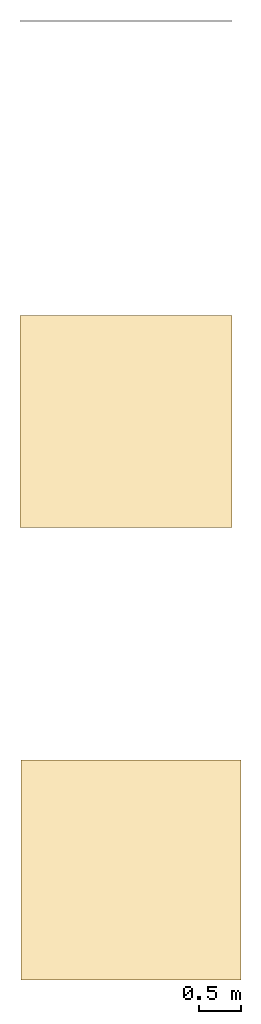
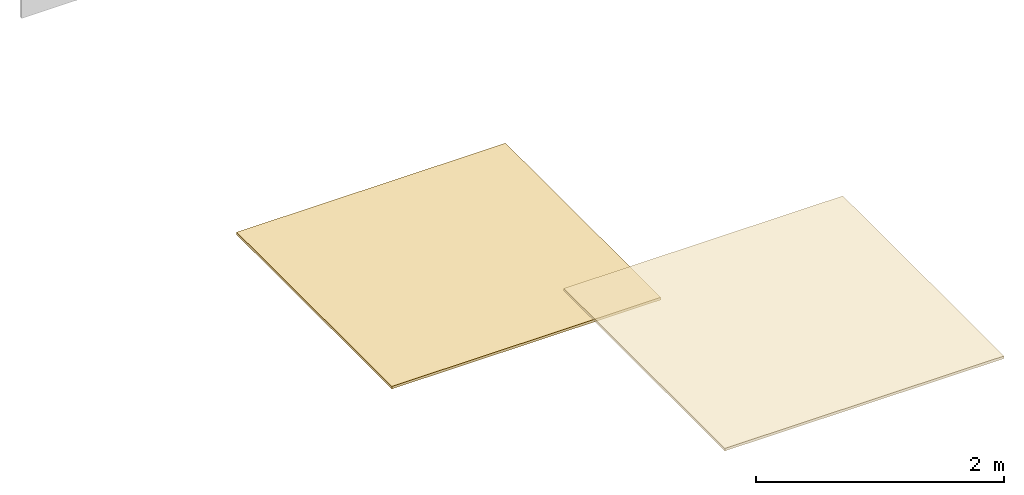
# One storey, part 2 of 2: 2 coverings.
"""IFC2X3 building model written with IfcOpenShell, lengths in millimetres."""

from ifc_helpers import new_model, entity, si_unit, converted_unit, derived_unit, direction, frame, frame_2d, origin, place, context, subcontext, project, spatial, rectangle, extrude, material, layer, layer_set, layer_usage, type_object, element, save


model = new_model("IFC2X3")

# Units and contexts
model_context = context("Model", 3, precision=0.01, world=origin(), true_north=direction((6.12303176911189e-17, 1.0)))
body_context = subcontext(model_context, "Body", "Model", "MODEL_VIEW")
ifc_project = project(units=[si_unit("LENGTHUNIT", "METRE", prefix="MILLI"), si_unit("AREAUNIT", "SQUARE_METRE"), si_unit("VOLUMEUNIT", "CUBIC_METRE"), converted_unit("PLANEANGLEUNIT", "DEGREE", entity("IfcRatioMeasure", 0.0174532925199433), si_unit("PLANEANGLEUNIT", "RADIAN"), dimensions=[0, 0, 0, 0, 0, 0, 0]), si_unit("MASSUNIT", "GRAM", prefix="KILO"), derived_unit("MASSDENSITYUNIT", [(si_unit("MASSUNIT", "GRAM", prefix="KILO"), 1), (si_unit("LENGTHUNIT", "METRE"), -3)]), si_unit("TIMEUNIT", "SECOND"), si_unit("FREQUENCYUNIT", "HERTZ"), si_unit("THERMODYNAMICTEMPERATUREUNIT", "DEGREE_CELSIUS"), derived_unit("THERMALTRANSMITTANCEUNIT", [(si_unit("MASSUNIT", "GRAM", prefix="KILO"), 1), (si_unit("THERMODYNAMICTEMPERATUREUNIT", "KELVIN"), -1), (si_unit("TIMEUNIT", "SECOND"), -3)]), derived_unit("VOLUMETRICFLOWRATEUNIT", [(si_unit("LENGTHUNIT", "METRE"), 3), (si_unit("TIMEUNIT", "SECOND"), -1)]), si_unit("ELECTRICCURRENTUNIT", "AMPERE"), si_unit("ELECTRICVOLTAGEUNIT", "VOLT"), si_unit("POWERUNIT", "WATT"), si_unit("FORCEUNIT", "NEWTON", prefix="KILO"), si_unit("ILLUMINANCEUNIT", "LUX"), si_unit("LUMINOUSFLUXUNIT", "LUMEN"), si_unit("LUMINOUSINTENSITYUNIT", "CANDELA"), derived_unit("USERDEFINED", [(si_unit("MASSUNIT", "GRAM", prefix="KILO"), -1), (si_unit("LENGTHUNIT", "METRE"), -2), (si_unit("TIMEUNIT", "SECOND"), 3), (si_unit("LUMINOUSFLUXUNIT", "LUMEN"), 1)]), derived_unit("LINEARVELOCITYUNIT", [(si_unit("LENGTHUNIT", "METRE"), 1), (si_unit("TIMEUNIT", "SECOND"), -1)]), si_unit("PRESSUREUNIT", "PASCAL"), derived_unit("USERDEFINED", [(si_unit("LENGTHUNIT", "METRE"), -2), (si_unit("MASSUNIT", "GRAM", prefix="KILO"), 1), (si_unit("TIMEUNIT", "SECOND"), -2)])], contexts=[model_context])

# Site, building, storey
site_placement = place(None, origin())
site = spatial("IfcSite", under=ifc_project, at=site_placement, CompositionType="ELEMENT")
building_placement = place(site_placement, origin())
building = spatial("IfcBuilding", under=site, at=building_placement, CompositionType="ELEMENT")
storey_placement = place(building_placement, origin())
storey = spatial("IfcBuildingStorey", under=building, at=storey_placement, Name="Level 0", CompositionType="ELEMENT", Elevation=0.0)

# Coverings
ifc_material = material()
ifc_layer_1 = layer(ifc_material, 25.0)
ifc_layer_set_1 = layer_set([ifc_layer_1])
ifc_layer_usage_1 = layer_usage(ifc_layer_set_1, "AXIS3", "POSITIVE", 0.0)
covering_type_1 = type_object("IfcCoveringType", PredefinedType="CEILING")
covering_1_placement = place(storey_placement, origin())
element("IfcCovering", 1, at=covering_1_placement, inside=storey, type_object=covering_type_1, material=ifc_layer_usage_1, PredefinedType="CEILING", context=body_context, shape_type="SweptSolid", body=[
    extrude(rectangle(XDim=2595.00000000001, YDim=2595.0, at=frame_2d((1.02318153949454e-12, 0.0), x_axis=(1.0, 0.0))), frame((1309.72112442895, -10831.7972568323, 2600.0), z_axis=(0.0, 0.0, 1.0), x_axis=(0.0, -1.0, 0.0)), (0.0, 0.0, 1.0), 24.9999999999997),
])
ifc_layer_2 = layer(ifc_material, 25.0)
ifc_layer_set_2 = layer_set([ifc_layer_2])
ifc_layer_usage_2 = layer_usage(ifc_layer_set_2, "AXIS3", "POSITIVE", 0.0)
covering_type_2 = type_object("IfcCoveringType", PredefinedType="INSULATION", material=ifc_layer_set_2)
covering_2_placement = place(storey_placement, origin())
element("IfcCovering", 2, at=covering_2_placement, inside=storey, type_object=covering_type_2, material=ifc_layer_usage_2, PredefinedType="INSULATION", context=body_context, shape_type="SweptSolid", body=[
    extrude(rectangle(XDim=2500.0, YDim=2500.0, at=frame_2d((-5.6843418860808e-13, 0.0), x_axis=(1.0, 0.0))), frame((1250.0, -5538.09808863256, 0.0), z_axis=(0.0, 0.0, -1.0), x_axis=(0.0, 1.0, 0.0)), (0.0, 0.0, 1.0), 25.0),
])

save(model, "model.ifc")
